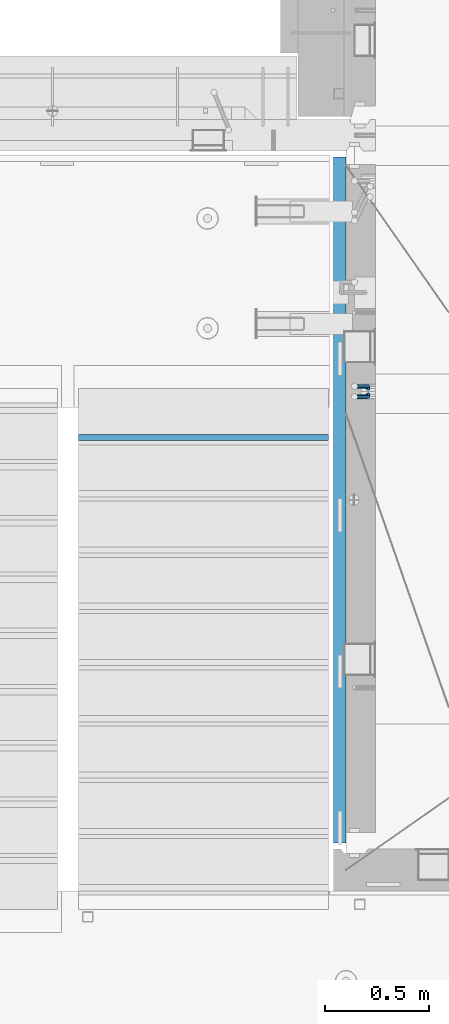
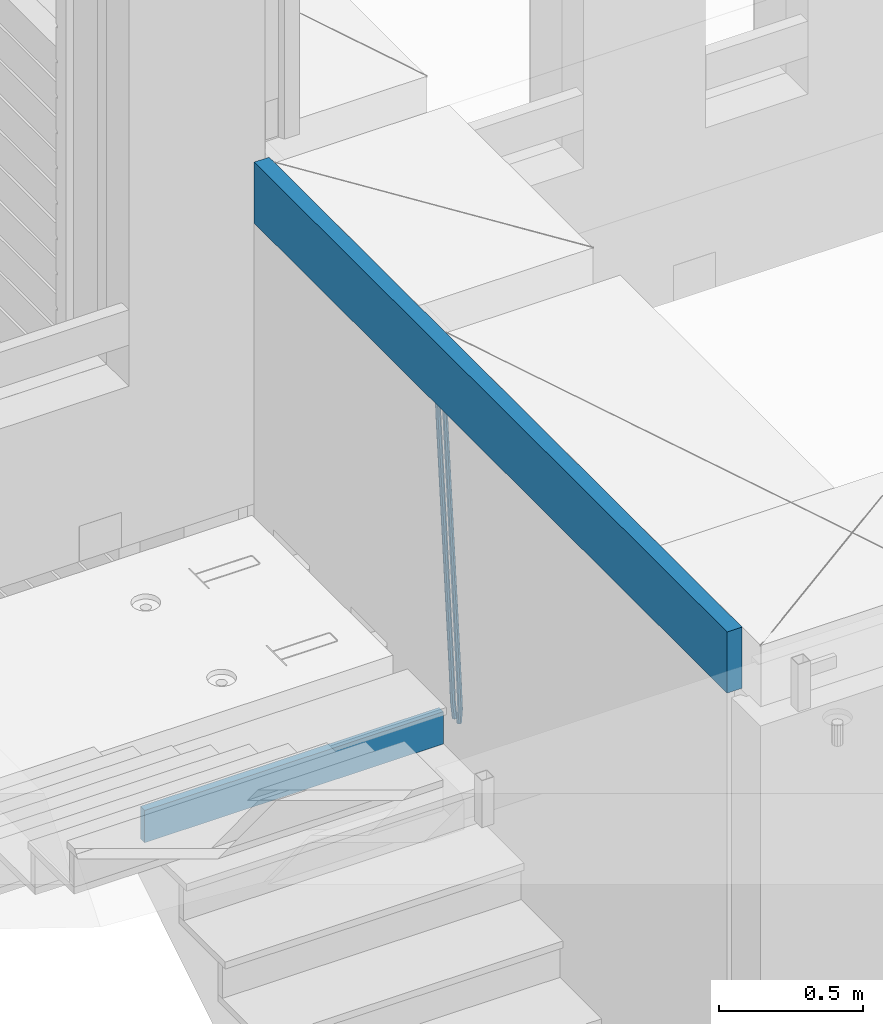
# One storey, part 119 of 352: 4 beams, 2 elements without a shape of their own.
"""IFC2X3 building model written with IfcOpenShell, lengths in millimetres."""

from ifc_helpers import new_model, si_unit, frame, origin_with_axes, place, context, subcontext, project, spatial, faceted_brep, material, type_object, element, aggregate, save


model = new_model("IFC2X3")

# Units and contexts
model_context = context("Model", 3, precision=1e-05, world=origin_with_axes())
body_context = subcontext(model_context, "Body", "Model", "MODEL_VIEW")
ifc_project = project(units=[si_unit("LENGTHUNIT", "METRE", prefix="MILLI"), si_unit("AREAUNIT", "SQUARE_METRE"), si_unit("VOLUMEUNIT", "CUBIC_METRE"), si_unit("MASSUNIT", "GRAM", prefix="KILO"), si_unit("TIMEUNIT", "SECOND"), si_unit("PLANEANGLEUNIT", "RADIAN"), si_unit("SOLIDANGLEUNIT", "STERADIAN"), si_unit("THERMODYNAMICTEMPERATUREUNIT", "DEGREE_CELSIUS"), si_unit("LUMINOUSINTENSITYUNIT", "LUMEN")], contexts=[model_context])

# Site, building, storey
site_placement = place(None, origin_with_axes())
site = spatial("IfcSite", under=ifc_project, at=site_placement, CompositionType="ELEMENT")
building_placement = place(site_placement, origin_with_axes())
building = spatial("IfcBuilding", under=site, at=building_placement, CompositionType="ELEMENT")
storey_placement = place(building_placement, origin_with_axes())
storey = spatial("IfcBuildingStorey", under=building, at=storey_placement, Name="6", CompositionType="ELEMENT", Elevation=0.0)

# Assembly, beams
assembly_1_placement = place(storey_placement, origin_with_axes())
assembly_1 = element("IfcElementAssembly", 1, at=assembly_1_placement, inside=storey, AssemblyPlace="NOTDEFINED", PredefinedType="REINFORCEMENT_UNIT")
ifc_material_1 = material()
beam_type_1 = type_object("IfcBeamType", Name="D20", PredefinedType="NOTDEFINED")
beam_1_placement = place(assembly_1_placement, frame((22375.0000022791, 19290.4700000039, 97985.0), z_axis=(-0.15890508605452, 0.973589036334047, -0.163931577056242), x_axis=(-0.0263727870048703, 0.161796289029781, 0.986471711181718)))
beam_1 = element("IfcBeam", 2, at=beam_1_placement, type_object=beam_type_1, material=ifc_material_1, Name="JM20", ObjectType="D20", context=body_context, shape_type="Brep", body=[
    faceted_brep([(0.0, -10.0, 0.0), (-4.19531716033816e-08, -7.07106781186667, -7.07106781187031), (60.5120847452927, -7.07106784077769, -7.0710678127632), (60.5120847456128, -10.000000028911, -8.96534402272664e-10), (0.0, 0.0, -10.0), (60.5120847479557, -2.89146555587649e-08, -10.0000000008984), (4.196772351861e-08, 7.07106781186303, -7.07106781186667), (60.5120847520593, 7.07106778294838, -7.0710678127632), (0.0, 10.0, 0.0), (60.5120847551734, 9.99999997108898, -8.94715412869118e-10), (4.196772351861e-08, 7.07106781185939, 7.07106781185939), (60.512084755479, 7.07106778295201, 7.07106781097195), (0.0, 0.0, 10.0), (60.512084752816, -2.89110175799578e-08, 9.9999999991071), (-4.19531716033816e-08, -7.07106781187031, 7.07106781185939), (60.5120847487415, -7.07106784077769, 7.07106781096832), (61.1107048256381, -7.07106784106145, -7.07106781277048), (61.616696962592, -10.0000000294385, -9.12905306904577e-10), (61.0120847479702, -2.91511241812259e-08, -10.0000000009038), (61.3786070335627, 7.07106778254092, -7.0710678127723), (61.9955678984406, 9.99999997037958, -9.2018126451876e-10), (62.5015600354091, 7.07106778200614, 7.07106781093921), (62.6001801130624, -2.9907823773101e-08, 9.99999999907436), (62.2336578274699, -7.07106784159623, 7.07106781094103), (61.7013993430301, -7.09359767751084, -7.16550506250837), (62.7066844218498, -10.0415735305724, -0.174261679103211), (61.505464887392, -0.0188181720659486, -10.0788791204338), (62.2336568017054, 7.03845510227256, -7.207768842012), (63.4594101385883, 9.94416717476997, -0.234031689273024), (64.464695217408, 6.99619132171574, 6.75721169413032), (64.6606296730461, -0.0785881837327906, 9.67058575205397), (63.9324377587182, -7.1358614580713, 6.79947547363395), (179.287252569251, -11.5784709304826, -25.9645361348155), (180.292537648071, -14.5264467835441, -18.973292751414), (179.091318113613, -4.50369142503769, -28.877910192741), (179.819510027926, 2.55358184929719, -26.0067999143191), (181.045263364809, 5.45929392180187, -19.033062761582), (182.050548443614, 2.511318068744, -12.0418193781786), (182.246482899252, -4.56346143670453, -9.12844532025679), (181.518290984939, -11.6207347110394, -11.9995555986786), (179.796944029818, -11.5979112078276, -26.0460230258138), (180.785917787493, -14.5452649264626, -19.0521718709458), (179.631039013402, -4.52427706319941, -28.9641980384947), (180.385387646791, 2.53199856077117, -26.0972695639282), (181.618102731314, 5.43744510340548, -19.1246454201662), (182.607076488988, 2.49009138477413, -12.1307942652963), (182.772981505375, -4.58354275985403, -9.21261925261729), (182.018632872001, -11.6398183838246, -12.0795477271802), (180.306575384253, -11.6215474691344, -26.1267734773298), (181.279244090445, -14.5681079330752, -19.1303214631914), (180.170689328603, -4.54931932109321, -29.0497458967745), (180.951186131948, 2.5057611781267, -26.1870011206463), (182.190861352254, 5.41092355571527, -19.2154962132006), (183.16353005846, 2.46436309177807, -12.2190441990567), (183.299416114096, -4.60786505625947, -9.29607177961748), (182.518919310765, -11.662945555483, -12.1588165557403), (300.637581828458, -17.193417372393, -45.2021641841727), (301.610250534635, -20.1399778363302, -38.2057121700307), (300.501695772793, -10.1211892243555, -48.125136603612), (301.282192576138, -3.06610872513556, -45.2623918274874), (302.521867796473, -0.160946347543359, -38.2908869200398), (303.494536502651, -3.10750681148056, -31.2944349058978), (303.630422558286, -10.1797349595217, -28.3714624864531), (302.849925754956, -17.2348154587417, -31.2342072625831), (301.135146648914, -17.2164568742628, -45.2810403078945), (302.103568397841, -20.1628206848691, -38.2839150477537), (301.007079483054, -10.1445907761881, -48.2052522115043), (301.794386909154, -3.08982563961035, -45.3435870847131), (303.035874914756, -0.184747202180006, -38.3723695478091), (304.004296663683, -3.13111101278264, -31.3752442876664), (304.132363829543, -10.2029771108573, -28.4510323840584), (303.345056403443, -17.2577422474315, -31.3126975108532), (301.632689949649, -17.2405558216851, -45.3597353949606), (302.596865217929, -20.1867113775443, -38.3619373656909), (301.512440876206, -10.1690694440185, -48.2851865283189), (302.306558273951, -3.11463305844518, -45.424601167904), (303.549858941391, -0.209639824737678, -38.4536714215171), (304.514034209686, -3.15579538060047, -31.4558733922438), (304.634283283129, -10.2272817582634, -28.5304222588836), (303.840165885384, -17.2817181438368, -31.3910076193022), (1282.62444446853, -64.7506719518351, -200.525713980774), (1283.58861973681, -67.6968275076943, -193.527915951503), (1282.50419539507, -57.6791855741649, -203.451165114133), (1283.29831279283, -50.6247491885915, -200.590579753716), (1284.54161346027, -47.7197559548877, -193.619650007329), (1285.50578872855, -50.6659115107432, -186.621851978058), (1285.62603780199, -57.7373978884098, -183.696400844703), (1284.83192040426, -64.7918342739831, -186.556986205121), (1283.16036625447, -64.7766270183929, -200.610482102403), (1284.18303170854, -67.7256152948248, -193.621935615638), (1282.99823367732, -57.703112193376, -203.529308414698), (1283.79160904189, -50.6486398706256, -200.668605684988), (1285.07574381966, -47.7456242614098, -193.704134774427), (1286.09840927372, -50.6946125378345, -186.715588287659), (1286.26054185088, -57.7681273628514, -183.796761975365), (1285.4671664863, -64.8225996856127, -186.657464705073), (1283.69517474226, -64.7992414390355, -200.702893843656), (1284.77620887742, -67.7506978399178, -193.72443311951), (1283.49124566819, -57.7239592457336, -203.61449796867), (1284.28388054106, -50.6694556112197, -200.753667286384), (1285.60876460234, -47.7681630887928, -193.796237610821), (1286.68979873748, -50.7196194896715, -186.817776886675), (1286.89372781155, -57.7949016829771, -183.906172761662), (1286.10109293868, -64.8494053174909, -186.767003443949), (1305.19726392522, -65.7084590385093, -204.418327587487), (1306.27829806038, -68.6599154393916, -197.43986686334), (1304.99333485115, -58.6331768452073, -207.3299317125), (1305.78596972401, -51.5786732107008, -204.469101030216), (1307.11085378527, -48.6773806882629, -197.511671354648), (1308.19188792045, -51.6288370891452, -190.533210630503), (1308.39581699451, -58.7041192824508, -187.62160650549), (1307.60318212165, -65.758622916961, -190.482437187782), (1305.83218118416, -65.7353065667266, -204.528037531872), (1306.8626665273, -68.6846255078017, -197.540842275655), (1305.64065308902, -58.6605487498273, -207.441784472648), (1306.40027680244, -51.6046492357418, -204.575249657393), (1307.66607505539, -48.7008582650778, -197.607610303868), (1308.69656039854, -51.6501772061529, -190.620415047653), (1308.88808849367, -58.7249350230522, -187.706668106881), (1308.12846478027, -65.7808345371377, -190.573202922138), (1306.46882402551, -65.7602792894941, -204.627733284394), (1307.44862319478, -68.7076100329687, -197.632600773693), (1306.28973061276, -58.6860092309689, -207.543427447275), (1307.01625344875, -51.6288113137889, -204.671709165457), (1308.2228053096, -48.7226963654903, -197.694792061111), (1309.20260447887, -51.6700271089649, -190.699659550409), (1309.38169789161, -58.74429716749, -187.783965387529), (1308.65517505561, -65.80149508467, -190.655683669345), (1405.22131312029, -69.6339088545756, -220.091982741469), (1406.20111228956, -72.5812395980538, -213.096850230768), (1405.04221970754, -62.5596387960541, -223.007676904353), (1405.76874254357, -55.5024408788704, -220.135958622533), (1406.97529440439, -52.5963259305718, -213.159041518189), (1407.95509357366, -55.54365667405, -206.163909007488), (1408.13418698641, -62.6179267325751, -203.248214844601), (1407.40766415041, -69.6751246497552, -206.119933126425)], [[[0, 1, 2, 3]], [[1, 4, 5, 2]], [[4, 6, 7, 5]], [[6, 8, 9, 7]], [[8, 10, 11, 9]], [[10, 12, 13, 11]], [[12, 14, 15, 13]], [[14, 0, 3, 15]], [[14, 12, 10, 8, 6, 4, 1, 0]], [[3, 2, 16, 17]], [[2, 5, 18, 16]], [[5, 7, 19, 18]], [[7, 9, 20, 19]], [[9, 11, 21, 20]], [[11, 13, 22, 21]], [[13, 15, 23, 22]], [[15, 3, 17, 23]], [[17, 16, 24, 25]], [[16, 18, 26, 24]], [[18, 19, 27, 26]], [[19, 20, 28, 27]], [[20, 21, 29, 28]], [[21, 22, 30, 29]], [[22, 23, 31, 30]], [[23, 17, 25, 31]], [[25, 24, 32, 33]], [[24, 26, 34, 32]], [[26, 27, 35, 34]], [[27, 28, 36, 35]], [[28, 29, 37, 36]], [[29, 30, 38, 37]], [[30, 31, 39, 38]], [[31, 25, 33, 39]], [[33, 32, 40, 41]], [[32, 34, 42, 40]], [[34, 35, 43, 42]], [[35, 36, 44, 43]], [[36, 37, 45, 44]], [[37, 38, 46, 45]], [[38, 39, 47, 46]], [[39, 33, 41, 47]], [[41, 40, 48, 49]], [[40, 42, 50, 48]], [[42, 43, 51, 50]], [[43, 44, 52, 51]], [[44, 45, 53, 52]], [[45, 46, 54, 53]], [[46, 47, 55, 54]], [[47, 41, 49, 55]], [[49, 48, 56, 57]], [[48, 50, 58, 56]], [[50, 51, 59, 58]], [[51, 52, 60, 59]], [[52, 53, 61, 60]], [[53, 54, 62, 61]], [[54, 55, 63, 62]], [[55, 49, 57, 63]], [[57, 56, 64, 65]], [[56, 58, 66, 64]], [[58, 59, 67, 66]], [[59, 60, 68, 67]], [[60, 61, 69, 68]], [[61, 62, 70, 69]], [[62, 63, 71, 70]], [[63, 57, 65, 71]], [[65, 64, 72, 73]], [[64, 66, 74, 72]], [[66, 67, 75, 74]], [[67, 68, 76, 75]], [[68, 69, 77, 76]], [[69, 70, 78, 77]], [[70, 71, 79, 78]], [[71, 65, 73, 79]], [[73, 72, 80, 81]], [[72, 74, 82, 80]], [[74, 75, 83, 82]], [[75, 76, 84, 83]], [[76, 77, 85, 84]], [[77, 78, 86, 85]], [[78, 79, 87, 86]], [[79, 73, 81, 87]], [[81, 80, 88, 89]], [[80, 82, 90, 88]], [[82, 83, 91, 90]], [[83, 84, 92, 91]], [[84, 85, 93, 92]], [[85, 86, 94, 93]], [[86, 87, 95, 94]], [[87, 81, 89, 95]], [[89, 88, 96, 97]], [[88, 90, 98, 96]], [[90, 91, 99, 98]], [[91, 92, 100, 99]], [[92, 93, 101, 100]], [[93, 94, 102, 101]], [[94, 95, 103, 102]], [[95, 89, 97, 103]], [[97, 96, 104, 105]], [[96, 98, 106, 104]], [[98, 99, 107, 106]], [[99, 100, 108, 107]], [[100, 101, 109, 108]], [[101, 102, 110, 109]], [[102, 103, 111, 110]], [[103, 97, 105, 111]], [[105, 104, 112, 113]], [[104, 106, 114, 112]], [[106, 107, 115, 114]], [[107, 108, 116, 115]], [[108, 109, 117, 116]], [[109, 110, 118, 117]], [[110, 111, 119, 118]], [[111, 105, 113, 119]], [[113, 112, 120, 121]], [[112, 114, 122, 120]], [[114, 115, 123, 122]], [[115, 116, 124, 123]], [[116, 117, 125, 124]], [[117, 118, 126, 125]], [[118, 119, 127, 126]], [[119, 113, 121, 127]], [[121, 120, 128, 129]], [[120, 122, 130, 128]], [[122, 123, 131, 130]], [[123, 124, 132, 131]], [[124, 125, 133, 132]], [[125, 126, 134, 133]], [[126, 127, 135, 134]], [[127, 121, 129, 135]], [[130, 131, 132, 133, 134, 135, 129, 128]]]),
])
beam_2_placement = place(assembly_1_placement, frame((22375.0000022791, 19260.4700000039, 97985.0), z_axis=(-0.158495816053634, -0.973655762329485, -0.163931488055477), x_axis=(-0.0263727879979646, -0.161796198987477, 0.986471725923465)))
beam_2 = element("IfcBeam", 3, at=beam_2_placement, type_object=beam_type_1, material=ifc_material_1, Name="JM20", ObjectType="D20", context=body_context, shape_type="Brep", body=[
    faceted_brep([(0.0, -10.0, 0.0), (-4.19531716033816e-08, -7.07106781186667, -7.07106781187031), (60.5120052037528, -7.07106781749098, -7.07106782543269), (60.5120052045822, -10.0000000056316, -1.35623849928379e-08), (0.0, 0.0, -10.0), (60.512005203942, -5.62431523576379e-09, -10.0000000135624), (4.196772351861e-08, 7.07106781186303, -7.07106781186667), (60.5120052050625, 7.07106780623872, -7.07106782543269), (0.0, 10.0, 0.0), (60.5120052064449, 9.99999999437205, -1.35623849928379e-08), (4.196772351861e-08, 7.07106781185939, 7.07106781185939), (60.5120052072889, 7.07106780623872, 7.07106779830065), (0.0, 0.0, 10.0), (60.5120052070852, -5.62795321457088e-09, 9.99999998643762), (-4.19531716033816e-08, -7.07106781187031, 7.07106781185939), (60.5120052059501, -7.07106781749098, 7.07106779830065), (61.3783176868601, -7.07106781757102, -7.07106782562914), (61.9952377020818, -10.0000000057662, -1.38970790430903e-08), (61.0120052039565, -5.67160896025598e-09, -10.0000000136788), (61.1108811377926, 7.07106780618051, -7.07106782556366), (61.6170253073215, 9.99999999427382, -1.38097675517201e-08), (62.2339453225432, 7.07106780607864, 7.07106779791502), (62.6002578054613, -5.81712811253965e-09, 9.99999998597195), (62.5013818716106, -7.07106781767652, 7.07106779785681), (62.2331604305218, -7.03851970548931, -7.2077492888784), (63.4588326085068, -9.94427367315438, -0.23401532828575), (61.5053853412101, 0.0187854284049536, -10.0788869429962), (61.7018281175842, 7.09356809489327, -7.16555479231465), (62.7074152454443, 10.041516558791, -0.174343299004249), (63.9330874234438, 7.13576259111869, 6.79939066157385), (64.6608625127556, 0.078457457228069, 9.6705283156989), (64.4644197363668, -6.99632520926025, 6.75719616502465), (179.818932802998, -2.5614449136192, -26.0086288006423), (181.044604980983, -5.46719888128791, -19.034894840057), (179.091157713687, 4.49586022027506, -28.8797664547601), (179.287600490061, 11.5706428867597, -25.9664343040859), (180.293187617921, 14.5185913506575, -18.9752228107754), (181.51885979592, 11.6128373829924, -12.0014888501901), (182.246634885232, 4.55553224909454, -9.13035119606502), (182.050192108843, -2.51925041739014, -12.0436833467465), (180.384803383684, -2.53989940806059, -26.0991062826724), (181.617449868121, -5.44538782921518, -19.126487449299), (179.630864755702, 4.51640954987306, -28.9660606284815), (179.797281007268, 11.5900489573214, -26.0479275136822), (180.786567755189, 14.5373767847341, -19.0541097400928), (182.019214239626, 11.6318883635759, -12.0814909067267), (182.773152867594, 4.5755794056422, -9.21453656090307), (182.606736616028, -2.49806000179888, -12.1326696757169), (180.950594849404, -2.51369963445904, -26.1888475202795), (182.190214025846, -5.41890367426822, -19.2173500092686), (180.170501221772, 4.54141556354443, -29.051616675737), (180.306901410135, 11.613651120846, -26.1286861303379), (181.279894034014, 14.5601873642845, -19.132268955691), (182.519513210456, 11.6549833244717, -12.16077144468), (183.299606838089, 4.59986812646821, -9.29800228921522), (183.163206649726, -2.4723674308334, -12.2209328346216), (301.281596738394, 3.05026059481679, -45.2665532172323), (302.521215914836, 0.145056555003976, -38.2950557062213), (300.501503110776, 10.1053757928166, -48.1293223726971), (300.637903299124, 17.1776113501182, -45.2063918272906), (301.610895923019, 20.1241475935603, -38.2099746526364), (302.850515099461, 17.2189435537439, -31.2384771416328), (303.630608727079, 10.163828355744, -28.375707986168), (303.494208538745, 3.09159279844243, -31.2986385315744), (301.793789297284, 3.07394376027514, -45.3477580501058), (303.035224417355, 0.168823687501572, -38.3765484452742), (301.006883331909, 10.128743964, -48.2094471532764), (301.135465363477, 17.2006180191747, -45.285277089446), (302.104213781728, 20.14695801567, -38.2881870233177), (303.345648901799, 17.2418379429, -31.3169774184789), (304.132554867159, 10.1870377391679, -28.455288315301), (304.003972835591, 3.11516368399316, -31.3794583791459), (302.305958891287, 3.09871749445665, -45.4287821432372), (303.549209831341, 0.193682665365486, -38.4578608624288), (301.512241238641, 10.1531893083702, -48.2893910778876), (301.633005909636, 17.2246841938904, -45.3639817491057), (302.597510597858, 20.1708163533331, -38.3662192661868), (303.840761537926, 17.2657815242455, -31.3952979853784), (304.634479190572, 10.211309710332, -28.5346890507208), (304.513714519577, 3.13981482481177, -31.4600983795099), (1283.29235311947, 50.544232039254, -200.613633821762), (1284.53560405952, 47.6391972101628, -193.642712540946), (1282.49863546679, 57.5987038531639, -203.474242756405), (1282.6194001378, 64.6701987386878, -200.548833427623), (1283.58390482602, 67.6163308981268, -193.551070944704), (1284.82715576609, 64.7112960690356, -186.580149663889), (1285.62087341874, 57.6568242551293, -183.719540729246), (1285.50010874774, 50.5853293696091, -186.644950058035), (1283.86584870378, 50.5719692160856, -200.704356616399), (1285.05399320807, 47.6642691581874, -193.72471790167), (1283.12497041782, 57.628996611762, -203.573324351266), (1283.26535480202, 64.701440406865, -200.651018717188), (1284.20476658808, 67.6463589453451, -193.649286721222), (1285.39291109238, 64.7386588874433, -186.6696480065), (1286.13378937833, 57.6816314917669, -183.800680271634), (1285.99340499415, 50.6091876966675, -186.722985905704), (1284.44060590031, 50.5936921758439, -200.788496023008), (1285.57352274218, 47.68390478734, -193.800772463459), (1283.75268322045, 57.6527210297136, -203.665215993606), (1283.91273047855, 64.7259079835276, -200.745788831606), (1284.82699416149, 67.6698760489453, -193.740375374167), (1285.95991100336, 64.7600886604341, -186.752651814619), (1286.64783368325, 57.7010598065717, -183.875931844028), (1286.48778642512, 50.6278728527504, -186.795359006021), (1306.02894027183, 51.4096237058839, -203.948838607132), (1307.16185711371, 48.4998363173727, -196.961115047583), (1305.34101759194, 58.4686525597535, -206.825558577722), (1305.50106485008, 65.5418395135639, -203.90613141573), (1306.415328533, 68.4858075789816, -196.900717958291), (1307.54824537487, 65.5760201904777, -189.912994398743), (1308.23616805475, 58.5169913366044, -187.036274428152), (1308.07612079663, 51.4438043827904, -189.955701590145), (1306.55429855913, 51.4294796328759, -204.025746447209), (1307.74597489809, 48.5219130607366, -197.046624762064), (1305.83539902292, 58.4873377158401, -206.897931678046), (1306.0103978878, 65.5610897659317, -203.980693299985), (1306.97678319212, 68.507027769072, -196.982909990227), (1308.16845953107, 65.5994611969327, -190.00378830509), (1308.88735906727, 58.5416031139684, -187.131603074253), (1308.71236020241, 51.4678510638769, -190.048841452306), (1307.07832423707, 51.4505295560484, -204.110977857723), (1308.32861102538, 48.5453173445967, -197.141389009383), (1306.32852641959, 58.507146466156, -206.978137563652), (1306.51843896537, 65.5814975934481, -204.063324856921), (1307.5368136808, 68.5295239925508, -197.073997489359), (1308.78710046913, 65.6243117811064, -190.104408641026), (1309.53689828661, 58.5676948709952, -187.237248935096), (1309.34698574082, 51.4933437436994, -190.152061641827), (1405.73383542724, 55.413485988287, -220.157039583137), (1406.98412221558, 52.5082737768425, -213.187450734797), (1404.98403760976, 62.4701028983982, -223.024199289066), (1405.17395015556, 69.544454025694, -220.109386582335), (1406.19232487098, 72.492480424793, -213.12005921478), (1407.44261165931, 69.5872682133449, -206.15047036644), (1408.1924094768, 62.5306513032374, -203.28331066051), (1408.00249693099, 55.4563001759452, -206.198123367241)], [[[0, 1, 2, 3]], [[1, 4, 5, 2]], [[4, 6, 7, 5]], [[6, 8, 9, 7]], [[8, 10, 11, 9]], [[10, 12, 13, 11]], [[12, 14, 15, 13]], [[14, 0, 3, 15]], [[14, 12, 10, 8, 6, 4, 1, 0]], [[3, 2, 16, 17]], [[2, 5, 18, 16]], [[5, 7, 19, 18]], [[7, 9, 20, 19]], [[9, 11, 21, 20]], [[11, 13, 22, 21]], [[13, 15, 23, 22]], [[15, 3, 17, 23]], [[17, 16, 24, 25]], [[16, 18, 26, 24]], [[18, 19, 27, 26]], [[19, 20, 28, 27]], [[20, 21, 29, 28]], [[21, 22, 30, 29]], [[22, 23, 31, 30]], [[23, 17, 25, 31]], [[25, 24, 32, 33]], [[24, 26, 34, 32]], [[26, 27, 35, 34]], [[27, 28, 36, 35]], [[28, 29, 37, 36]], [[29, 30, 38, 37]], [[30, 31, 39, 38]], [[31, 25, 33, 39]], [[33, 32, 40, 41]], [[32, 34, 42, 40]], [[34, 35, 43, 42]], [[35, 36, 44, 43]], [[36, 37, 45, 44]], [[37, 38, 46, 45]], [[38, 39, 47, 46]], [[39, 33, 41, 47]], [[41, 40, 48, 49]], [[40, 42, 50, 48]], [[42, 43, 51, 50]], [[43, 44, 52, 51]], [[44, 45, 53, 52]], [[45, 46, 54, 53]], [[46, 47, 55, 54]], [[47, 41, 49, 55]], [[49, 48, 56, 57]], [[48, 50, 58, 56]], [[50, 51, 59, 58]], [[51, 52, 60, 59]], [[52, 53, 61, 60]], [[53, 54, 62, 61]], [[54, 55, 63, 62]], [[55, 49, 57, 63]], [[57, 56, 64, 65]], [[56, 58, 66, 64]], [[58, 59, 67, 66]], [[59, 60, 68, 67]], [[60, 61, 69, 68]], [[61, 62, 70, 69]], [[62, 63, 71, 70]], [[63, 57, 65, 71]], [[65, 64, 72, 73]], [[64, 66, 74, 72]], [[66, 67, 75, 74]], [[67, 68, 76, 75]], [[68, 69, 77, 76]], [[69, 70, 78, 77]], [[70, 71, 79, 78]], [[71, 65, 73, 79]], [[73, 72, 80, 81]], [[72, 74, 82, 80]], [[74, 75, 83, 82]], [[75, 76, 84, 83]], [[76, 77, 85, 84]], [[77, 78, 86, 85]], [[78, 79, 87, 86]], [[79, 73, 81, 87]], [[81, 80, 88, 89]], [[80, 82, 90, 88]], [[82, 83, 91, 90]], [[83, 84, 92, 91]], [[84, 85, 93, 92]], [[85, 86, 94, 93]], [[86, 87, 95, 94]], [[87, 81, 89, 95]], [[89, 88, 96, 97]], [[88, 90, 98, 96]], [[90, 91, 99, 98]], [[91, 92, 100, 99]], [[92, 93, 101, 100]], [[93, 94, 102, 101]], [[94, 95, 103, 102]], [[95, 89, 97, 103]], [[97, 96, 104, 105]], [[96, 98, 106, 104]], [[98, 99, 107, 106]], [[99, 100, 108, 107]], [[100, 101, 109, 108]], [[101, 102, 110, 109]], [[102, 103, 111, 110]], [[103, 97, 105, 111]], [[105, 104, 112, 113]], [[104, 106, 114, 112]], [[106, 107, 115, 114]], [[107, 108, 116, 115]], [[108, 109, 117, 116]], [[109, 110, 118, 117]], [[110, 111, 119, 118]], [[111, 105, 113, 119]], [[113, 112, 120, 121]], [[112, 114, 122, 120]], [[114, 115, 123, 122]], [[115, 116, 124, 123]], [[116, 117, 125, 124]], [[117, 118, 126, 125]], [[118, 119, 127, 126]], [[119, 113, 121, 127]], [[121, 120, 128, 129]], [[120, 122, 130, 128]], [[122, 123, 131, 130]], [[123, 124, 132, 131]], [[124, 125, 133, 132]], [[125, 126, 134, 133]], [[126, 127, 135, 134]], [[127, 121, 129, 135]], [[130, 131, 132, 133, 134, 135, 129, 128]]]),
])
ifc_material_2 = material(Name="CONCRETE/C25/30")
beam_type_2 = type_object("IfcBeamType", Name="260X60", PredefinedType="NOTDEFINED")
beam_3_placement = place(assembly_1_placement, frame((22240.0000000001, 20400.0, 99600.0), z_axis=(0.0, 0.0, 1.0), x_axis=(0.0, -1.0, 0.0)))
beam_3 = element("IfcBeam", 4, at=beam_3_placement, type_object=beam_type_2, material=ifc_material_2, ObjectType="260X60", context=body_context, shape_type="Brep", body=[
    faceted_brep([(0.0, 30.0, -130.0), (0.0, 30.0, 130.0), (3290.0, 30.0, 130.0), (3290.0, 30.0, -130.0), (0.0, -30.0, 130.0), (3290.0, -30.0, 130.0), (0.0, -30.0, -130.0), (3290.0, -30.0, -130.0)], [[[0, 1, 2, 3]], [[1, 4, 5, 2]], [[4, 6, 7, 5]], [[6, 0, 3, 7]], [[5, 7, 3, 2]], [[6, 4, 1, 0]]]),
])
aggregate(assembly_1, [beam_1, beam_2, beam_3])

# Assembly, beam
assembly_2_placement = place(storey_placement, origin_with_axes())
assembly_2 = element("IfcElementAssembly", 5, at=assembly_2_placement, inside=storey, Name="E9", AssemblyPlace="NOTDEFINED", PredefinedType="NOTDEFINED")
ifc_material_3 = material(Name="Undefined/C32/40")
beam_type_3 = type_object("IfcBeamType", PredefinedType="NOTDEFINED")
beam_4_placement = place(assembly_2_placement, frame((20985.002175553, 19055.001025346, 98161.803607297), z_axis=(0.0, -1.0, 0.0), x_axis=(1.0, 0.0, 0.0)))
beam_4 = element("IfcBeam", 6, at=beam_4_placement, type_object=beam_type_3, material=ifc_material_3, Name="E9", context=body_context, shape_type="Brep", body=[
    faceted_brep([(0.0, 68.5, -15.0), (0.0, 68.5, 15.0), (1200.0, 68.5, 15.0), (1200.0, 68.5, -15.0), (0.0, -68.5, 15.0), (1200.0, -68.5, 15.0), (0.0, -68.5, -15.0), (1200.0, -68.5, -15.0)], [[[0, 1, 2, 3]], [[1, 4, 5, 2]], [[4, 6, 7, 5]], [[6, 0, 3, 7]], [[5, 7, 3, 2]], [[6, 4, 1, 0]]]),
])
aggregate(assembly_2, [beam_4])

save(model, "model.ifc")
